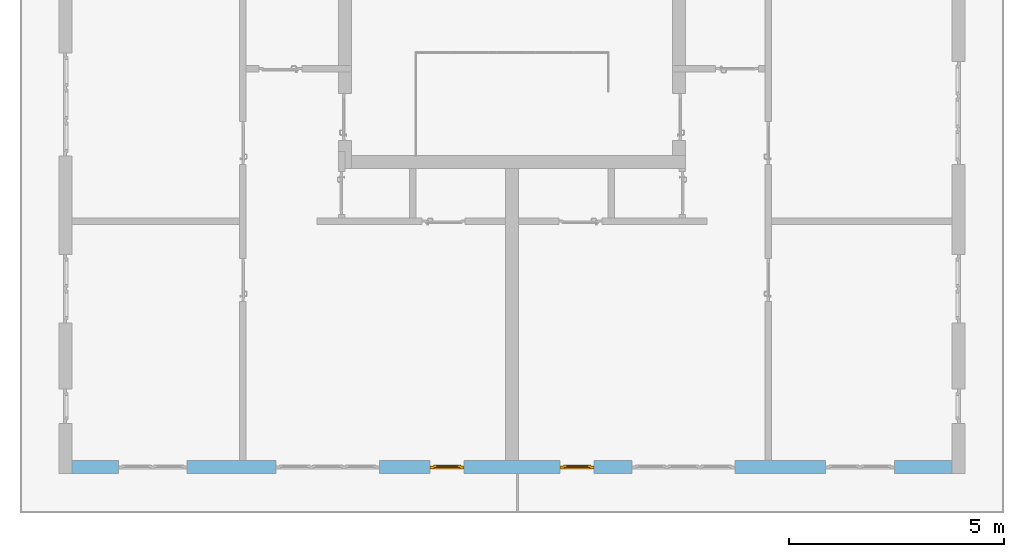
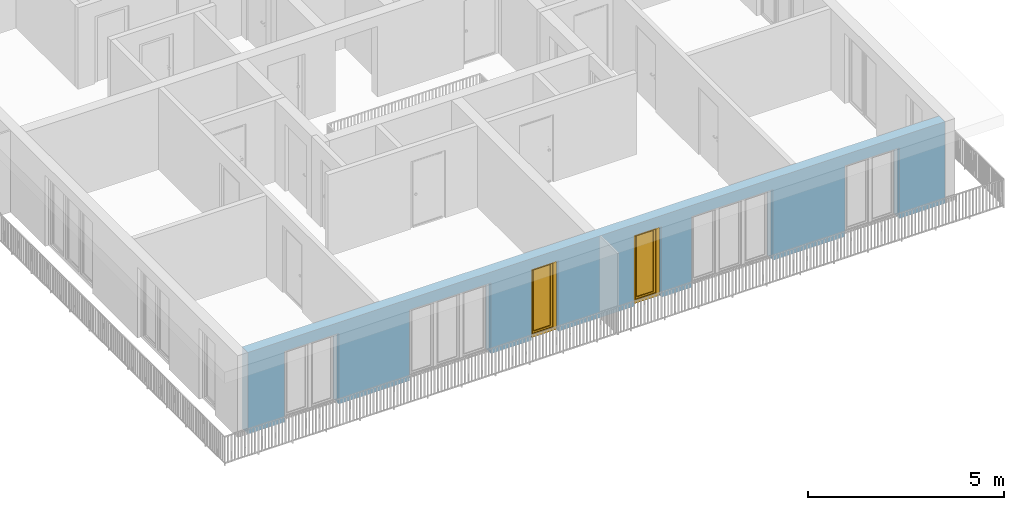
# One storey, part 10 of 54: 2 windows, 6 openings, plus 1 element that does not belong to this part.
"""IFC4 building model written with IfcOpenShell, lengths in metres."""

from ifc_helpers import new_model, entity, si_unit, converted_unit, derived_unit, direction, frame, origin_with_axes, place, context, subcontext, project, spatial, polygons, source, transform, mapped, material, type_object, element, fill, save


model = new_model("IFC4")

# Units and contexts
model_context = context("Model", 3, precision=1e-05, world=origin_with_axes(), true_north=direction((0.0, 1.0)))
body_context = subcontext(model_context, "Body", "Model", "MODEL_VIEW")
ifc_project = project(units=[si_unit("LENGTHUNIT", "METRE"), si_unit("AREAUNIT", "SQUARE_METRE"), si_unit("VOLUMEUNIT", "CUBIC_METRE"), converted_unit("PLANEANGLEUNIT", "DEGREE", entity("IfcPlaneAngleMeasure", 0.0174532925199), si_unit("PLANEANGLEUNIT", "RADIAN"), dimensions=[0, 0, 0, 0, 0, 0, 0]), converted_unit("TIMEUNIT", "Year", entity("IfcTimeMeasure", 31556926.0), si_unit("TIMEUNIT", "SECOND"), dimensions=[0, 0, 1, 0, 0, 0, 0]), si_unit("MASSUNIT", "GRAM", prefix="KILO"), si_unit("THERMODYNAMICTEMPERATUREUNIT", "DEGREE_CELSIUS"), si_unit("LUMINOUSINTENSITYUNIT", "LUMEN"), si_unit("ENERGYUNIT", "JOULE", prefix="MEGA"), derived_unit("THERMALCONDUCTANCEUNIT", [(si_unit("POWERUNIT", "WATT"), 1), (si_unit("LENGTHUNIT", "METRE"), -1), (si_unit("THERMODYNAMICTEMPERATUREUNIT", "KELVIN"), -1)]), derived_unit("SPECIFICHEATCAPACITYUNIT", [(si_unit("ENERGYUNIT", "JOULE"), 1), (si_unit("MASSUNIT", "GRAM", prefix="KILO"), -1), (si_unit("THERMODYNAMICTEMPERATUREUNIT", "KELVIN"), -1)]), derived_unit("MASSDENSITYUNIT", [(si_unit("MASSUNIT", "GRAM", prefix="KILO"), 1), (si_unit("VOLUMEUNIT", "CUBIC_METRE"), -1)])], contexts=[model_context])

# Site, building, storey
site_placement = place(None, origin_with_axes())
site = spatial("IfcSite", under=ifc_project, at=site_placement, CompositionType="ELEMENT")
building_placement = place(site_placement, origin_with_axes())
building = spatial("IfcBuilding", under=site, at=building_placement, CompositionType="ELEMENT")
storey_placement = place(building_placement, frame((0.0, 0.0, 9.18), z_axis=(0.0, 0.0, 1.0), x_axis=(1.0, 0.0, 0.0)))
storey = spatial("IfcBuildingStorey", under=building, at=storey_placement, Name="3. Geschoss", CompositionType="ELEMENT", Elevation=9.18)

# Wall, openings, windows
ifc_material = material()
wall_type = type_object("IfcWallType", Name="300", PredefinedType="NOTDEFINED")
wall_placement = place(storey_placement, frame((9.3378006196, -9.92881223104, 0.0), z_axis=(0.0, 0.0, 1.0), x_axis=(-1.0, 0.0, 0.0)))
wall = element("IfcWall", 1, at=wall_placement, inside=storey, type_object=wall_type, material=ifc_material, Name="Wand-001", PredefinedType="NOTDEFINED", context=body_context, shape_type="Tessellation", body=[
    polygons([(12.4515538751, -0.3, 2.2), (12.4515538751, -0.3, 0.0), (13.63, -0.3, 0.0), (13.63, -0.3, 2.2), (16.03, -0.3, 2.2), (16.03, -0.3, 0.0), (18.0998837323, -0.3, 0.0), (18.0998837323, -0.3, 2.2), (19.6998837323, -0.3, 2.2), (19.6998837323, -0.3, 0.0), (20.78, -0.3, 0.0), (20.78, -0.3, 2.54), (0.3, -0.3, 2.54), (0.3, -0.3, 0.0), (1.6378225413, -0.3, 0.0), (1.6378225413, -0.3, 2.2), (3.2378225413, -0.3, 2.2), (3.2378225413, -0.3, 0.0), (5.35, -0.3, 0.0), (5.35, -0.3, 2.2), (7.75, -0.3, 2.2), (7.75, -0.3, 0.0), (8.62617854928, -0.3, 0.0), (8.62617854928, -0.3, 2.2), (9.42617854928, -0.3, 2.2), (9.42617854928, -0.3, 0.0), (11.6515538751, -0.3, 0.0), (11.6515538751, -0.3, 2.2), (12.4515538751, -0.1, 0.0), (12.4515538751, 0.0, 2.2), (12.4515538751, 0.0, 0.0), (13.63, 0.0, 0.0), (13.63, 0.0, 2.2), (16.03, 0.0, 2.2), (16.03, 0.0, 0.0), (18.0998837323, 0.0, 0.0), (18.0998837323, 0.0, 2.2), (19.6998837323, 0.0, 2.2), (19.6998837323, 0.0, 0.0), (20.78, 0.0, 0.0), (20.78, 0.0, 2.54), (0.3, 0.0, 2.54), (0.3, 0.0, 0.0), (1.6378225413, 0.0, 0.0), (1.6378225413, 0.0, 2.2), (3.2378225413, 0.0, 2.2), (3.2378225413, 0.0, 0.0), (5.35, 0.0, 0.0), (5.35, 0.0, 2.2), (7.75, 0.0, 2.2), (7.75, 0.0, 0.0), (8.62617854928, 0.0, 0.0), (8.62617854928, 0.0, 2.2), (9.42617854928, 0.0, 2.2), (9.42617854928, 0.0, 0.0), (11.6515538751, -0.1, 0.0), (11.6515538751, 0.0, 0.0), (11.6515538751, 0.0, 2.2)], [[[1, 2, 3, 4, 5, 6, 7, 8, 9, 10, 11, 12, 13, 14, 15, 16, 17, 18, 19, 20, 21, 22, 23, 24, 25, 26, 27, 28]], [[29, 2, 1, 30, 31]], [[2, 29, 31, 32, 3]], [[32, 33, 4, 3]], [[33, 34, 5, 4]], [[34, 35, 6, 5]], [[36, 7, 6, 35]], [[36, 37, 8, 7]], [[37, 38, 9, 8]], [[38, 39, 10, 9]], [[40, 11, 10, 39]], [[40, 41, 12, 11]], [[41, 42, 13, 12]], [[14, 13, 42, 43]], [[15, 14, 43, 44]], [[16, 15, 44, 45]], [[17, 16, 45, 46]], [[18, 17, 46, 47]], [[19, 18, 47, 48]], [[20, 19, 48, 49]], [[21, 20, 49, 50]], [[22, 21, 50, 51]], [[51, 52, 23, 22]], [[52, 53, 24, 23]], [[53, 54, 25, 24]], [[54, 55, 26, 25]], [[56, 27, 26, 55, 57]], [[28, 27, 56, 57, 58]], [[1, 28, 58, 30]], [[32, 31, 30, 58, 57, 55, 54, 53, 52, 51, 50, 49, 48, 47, 46, 45, 44, 43, 42, 41, 40, 39, 38, 37, 36, 35, 34, 33]]], closed=True),
])
opening_1_placement = place(wall_placement, frame((18.8998837323, 0.0, 0.0), z_axis=(0.0, 0.0, 1.0), x_axis=(1.0, 0.0, 0.0)))
element("IfcOpeningElement", 2, at=opening_1_placement, cuts=wall, Name="Fenster-001", context=body_context, identifier="Reference", shape_type="Tessellation", body=[
    polygons([(-0.8, -0.1, 0.0), (-0.8, -0.1, 2.2), (-0.8, 0.001, 2.2), (-0.8, 0.001, 0.0), (-0.8, -0.301, 0.0), (-0.8, -0.301, 2.2), (0.8, -0.1, 2.2), (0.8, 0.001, 2.2), (0.8, -0.301, 2.2), (0.8, 0.001, 0.0), (0.8, -0.1, 0.0), (0.8, -0.301, 0.0)], [[[1, 2, 3, 4]], [[2, 1, 5, 6]], [[7, 8, 3, 2, 6, 9]], [[8, 10, 4, 3]], [[1, 4, 10, 11, 12, 5]], [[6, 5, 12, 9]], [[7, 11, 10, 8]], [[11, 7, 9, 12]]], closed=True),
])
opening_2_placement = place(wall_placement, frame((2.4378225413, 0.0, 0.0), z_axis=(0.0, 0.0, 1.0), x_axis=(1.0, 0.0, 0.0)))
element("IfcOpeningElement", 3, at=opening_2_placement, cuts=wall, Name="Fenster-002", context=body_context, identifier="Reference", shape_type="Tessellation", body=[
    polygons([(-0.8, -0.1, 0.0), (-0.8, -0.1, 2.2), (-0.8, 0.000999999999999, 2.2), (-0.8, 0.000999999999999, 0.0), (-0.8, -0.301, 0.0), (-0.8, -0.301, 2.2), (0.8, -0.1, 2.2), (0.8, 0.000999999999999, 2.2), (0.8, -0.301, 2.2), (0.8, 0.000999999999999, 0.0), (0.8, -0.1, 0.0), (0.8, -0.301, 0.0)], [[[1, 2, 3, 4]], [[2, 1, 5, 6]], [[7, 8, 3, 2, 6, 9]], [[8, 10, 4, 3]], [[1, 4, 10, 11, 12, 5]], [[6, 5, 12, 9]], [[7, 11, 10, 8]], [[11, 7, 9, 12]]], closed=True),
])
opening_3_placement = place(wall_placement, frame((14.83, 0.0, 0.0), z_axis=(0.0, 0.0, 1.0), x_axis=(1.0, 0.0, 0.0)))
element("IfcOpeningElement", 4, at=opening_3_placement, cuts=wall, Name="Fenster-002", context=body_context, identifier="Reference", shape_type="Tessellation", body=[
    polygons([(-1.2, -0.1, 0.0), (-1.2, -0.1, 2.2), (-1.2, 0.001, 2.2), (-1.2, 0.001, 0.0), (-1.2, -0.301, 0.0), (-1.2, -0.301, 2.2), (1.2, -0.1, 2.2), (1.2, 0.001, 2.2), (1.2, -0.301, 2.2), (1.2, 0.001, 0.0), (1.2, -0.1, 0.0), (1.2, -0.301, 0.0)], [[[1, 2, 3, 4]], [[2, 1, 5, 6]], [[7, 8, 3, 2, 6, 9]], [[8, 10, 4, 3]], [[1, 4, 10, 11, 12, 5]], [[6, 5, 12, 9]], [[7, 11, 10, 8]], [[11, 7, 9, 12]]], closed=True),
])
opening_4_placement = place(wall_placement, frame((6.55, 0.0, 0.0), z_axis=(0.0, 0.0, 1.0), x_axis=(1.0, 0.0, 0.0)))
element("IfcOpeningElement", 5, at=opening_4_placement, cuts=wall, Name="Fenster-003", context=body_context, identifier="Reference", shape_type="Tessellation", body=[
    polygons([(-1.2, -0.1, 0.0), (-1.2, -0.1, 2.2), (-1.2, 0.000999999999999, 2.2), (-1.2, 0.000999999999999, 0.0), (-1.2, -0.301, 0.0), (-1.2, -0.301, 2.2), (1.2, -0.1, 2.2), (1.2, 0.001, 2.2), (1.2, -0.301, 2.2), (1.2, 0.001, 0.0), (1.2, -0.1, 0.0), (1.2, -0.301, 0.0)], [[[1, 2, 3, 4]], [[2, 1, 5, 6]], [[7, 8, 3, 2, 6, 9]], [[8, 10, 4, 3]], [[1, 4, 10, 11, 12, 5]], [[6, 5, 12, 9]], [[7, 11, 10, 8]], [[11, 7, 9, 12]]], closed=True),
])
opening_5_placement = place(wall_placement, frame((9.02617854928, 0.0, 0.0), z_axis=(0.0, 0.0, 1.0), x_axis=(1.0, 0.0, 0.0)))
opening_5 = element("IfcOpeningElement", 6, at=opening_5_placement, cuts=wall, Name="Fenster-003", context=body_context, identifier="Reference", shape_type="Tessellation", body=[
    polygons([(-0.4, -0.1, 0.0), (-0.4, -0.1, 2.2), (-0.4, 0.001, 2.2), (-0.4, 0.001, 0.0), (-0.4, -0.301, 0.0), (-0.4, -0.301, 2.2), (0.4, -0.1, 2.2), (0.4, 0.001, 2.2), (0.4, -0.301, 2.2), (0.4, 0.001, 0.0), (0.4, -0.1, 0.0), (0.4, -0.301, 0.0)], [[[1, 2, 3, 4]], [[2, 1, 5, 6]], [[7, 8, 3, 2, 6, 9]], [[8, 10, 4, 3]], [[1, 4, 10, 11, 12, 5]], [[6, 5, 12, 9]], [[7, 11, 10, 8]], [[11, 7, 9, 12]]], closed=True),
])
opening_6_placement = place(wall_placement, frame((12.0515538751, 0.0, 0.0), z_axis=(0.0, 0.0, 1.0), x_axis=(1.0, 0.0, 0.0)))
opening_6 = element("IfcOpeningElement", 7, at=opening_6_placement, cuts=wall, Name="Fenster-003", context=body_context, identifier="Reference", shape_type="Tessellation", body=[
    polygons([(-0.4, -0.1, 0.0), (-0.4, -0.1, 2.2), (-0.4, 0.001, 2.2), (-0.4, 0.001, 0.0), (-0.4, -0.301, 0.0), (-0.4, -0.301, 2.2), (0.4, -0.1, 2.2), (0.4, 0.001, 2.2), (0.4, -0.301, 2.2), (0.4, 0.001, 0.0), (0.4, -0.1, 0.0), (0.4, -0.301, 0.0)], [[[1, 2, 3, 4]], [[2, 1, 5, 6]], [[7, 8, 3, 2, 6, 9]], [[8, 10, 4, 3]], [[1, 4, 10, 11, 12, 5]], [[6, 5, 12, 9]], [[7, 11, 10, 8]], [[11, 7, 9, 12]]], closed=True),
])
window_type = type_object("IfcWindowType", Name="1-26", PartitioningType="SINGLE_PANEL", PredefinedType="WINDOW")
shared_shape = source(origin_with_axes(), body_context, "Body", "Tessellation", [
    polygons([(-0.4, -0.07, 0.0), (-0.4, 0.0, 0.0), (-0.3, 0.0, 0.1), (-0.3, -0.07, 0.1), (-0.4, -0.07, 2.2), (-0.4, 0.0, 2.2), (-0.3, 0.0, 2.1), (-0.3, -0.07, 2.1)], [[[1, 2, 3, 4]], [[5, 6, 2, 1]], [[2, 6, 7, 3]], [[4, 3, 7, 8]], [[1, 4, 8, 5]], [[8, 7, 6, 5]]], closed=True),
    polygons([(0.4, -0.07, 0.0), (0.4, 0.0, 0.0), (0.4, 0.0, 2.2), (0.4, -0.07, 2.2), (0.3, -0.07, 0.1), (0.3, 0.0, 0.1), (0.3, 0.0, 2.1), (0.3, -0.07, 2.1)], [[[1, 2, 3, 4]], [[5, 6, 2, 1]], [[2, 6, 7, 3]], [[4, 3, 7, 8]], [[1, 4, 8, 5]], [[8, 7, 6, 5]]], closed=True),
    polygons([(-0.4, -0.07, 0.0), (-0.4, 0.0, 0.0), (0.4, 0.0, 0.0), (0.4, -0.07, 0.0), (-0.3, -0.07, 0.1), (-0.3, 0.0, 0.1), (0.0, 0.0, 0.1), (0.3, 0.0, 0.1), (0.3, -0.07, 0.1), (0.0, -0.07, 0.1)], [[[1, 2, 3, 4]], [[5, 6, 2, 1]], [[2, 6, 7, 8, 3]], [[4, 3, 8, 9]], [[1, 4, 9, 10, 5]], [[10, 7, 6, 5]], [[9, 8, 7, 10]]], closed=True),
    polygons([(-0.4, -0.07, 2.2), (-0.4, 0.0, 2.2), (-0.3, 0.0, 2.1), (-0.3, -0.07, 2.1), (0.4, -0.07, 2.2), (0.4, 0.0, 2.2), (0.3, 0.0, 2.1), (0.0, 0.0, 2.1), (0.0, -0.07, 2.1), (0.3, -0.07, 2.1)], [[[1, 2, 3, 4]], [[5, 6, 2, 1]], [[2, 6, 7, 8, 3]], [[4, 3, 8, 9]], [[1, 4, 9, 10, 5]], [[10, 7, 6, 5]], [[9, 8, 7, 10]]], closed=True),
    polygons([(-0.32, 0.0, 0.08), (-0.32, 0.03, 0.08), (-0.25, 0.03, 0.15), (-0.25, 0.0, 0.15), (-0.32, 0.0, 2.12), (-0.32, 0.03, 2.12), (-0.25, 0.03, 2.05), (-0.25, 0.0, 2.05)], [[[1, 2, 3, 4]], [[5, 6, 2, 1]], [[2, 6, 7, 3]], [[4, 3, 7, 8]], [[1, 4, 8, 5]], [[8, 7, 6, 5]]], closed=True),
    polygons([(0.32, 0.0, 0.08), (0.25, 0.0, 0.15), (0.25, 0.03, 0.15), (0.32, 0.03, 0.08), (0.32, 0.0, 2.12), (0.25, 0.0, 2.05), (0.25, 0.03, 2.05), (0.32, 0.03, 2.12)], [[[1, 2, 3, 4]], [[1, 5, 6, 2]], [[2, 6, 7, 3]], [[4, 3, 7, 8]], [[5, 1, 4, 8]], [[6, 5, 8, 7]]], closed=True),
    polygons([(-0.32, 0.0, 0.08), (-0.32, 0.03, 0.08), (0.32, 0.03, 0.08), (0.32, 0.0, 0.08), (-0.25, 0.0, 0.15), (-0.25, 0.03, 0.15), (0.25, 0.03, 0.15), (0.25, 0.0, 0.15)], [[[1, 2, 3, 4]], [[5, 6, 2, 1]], [[2, 6, 7, 3]], [[4, 3, 7, 8]], [[1, 4, 8, 5]], [[8, 7, 6, 5]]], closed=True),
    polygons([(-0.32, 0.0, 2.12), (0.32, 0.0, 2.12), (0.32, 0.03, 2.12), (-0.32, 0.03, 2.12), (-0.25, 0.0, 2.05), (0.25, 0.0, 2.05), (0.25, 0.03, 2.05), (-0.25, 0.03, 2.05)], [[[1, 2, 3, 4]], [[1, 5, 6, 2]], [[2, 6, 7, 3]], [[4, 3, 7, 8]], [[5, 1, 4, 8]], [[6, 5, 8, 7]]], closed=True),
    polygons([(-0.3, -0.03, 0.1), (-0.3, 0.0, 0.1), (-0.25, 0.0, 0.15), (-0.25, -0.03, 0.15), (-0.3, -0.03, 2.1), (-0.3, 0.0, 2.1), (-0.25, 0.0, 2.05), (-0.25, -0.03, 2.05)], [[[1, 2, 3, 4]], [[5, 6, 2, 1]], [[2, 6, 7, 3]], [[4, 3, 7, 8]], [[1, 4, 8, 5]], [[8, 7, 6, 5]]], closed=True),
    polygons([(0.3, -0.03, 0.1), (0.25, -0.03, 0.15), (0.25, 0.0, 0.15), (0.3, 0.0, 0.1), (0.3, -0.03, 2.1), (0.25, -0.03, 2.05), (0.25, 0.0, 2.05), (0.3, 0.0, 2.1)], [[[1, 2, 3, 4]], [[1, 5, 6, 2]], [[2, 6, 7, 3]], [[4, 3, 7, 8]], [[5, 1, 4, 8]], [[6, 5, 8, 7]]], closed=True),
    polygons([(-0.3, -0.03, 0.1), (-0.3, 0.0, 0.1), (0.3, 0.0, 0.1), (0.3, -0.03, 0.1), (-0.25, -0.03, 0.15), (-0.25, 0.0, 0.15), (0.25, 0.0, 0.15), (0.25, -0.03, 0.15)], [[[1, 2, 3, 4]], [[5, 6, 2, 1]], [[2, 6, 7, 3]], [[4, 3, 7, 8]], [[1, 4, 8, 5]], [[8, 7, 6, 5]]], closed=True),
    polygons([(-0.3, -0.03, 2.1), (0.3, -0.03, 2.1), (0.3, 0.0, 2.1), (-0.3, 0.0, 2.1), (-0.25, -0.03, 2.05), (0.25, -0.03, 2.05), (0.25, 0.0, 2.05), (-0.25, 0.0, 2.05)], [[[1, 2, 3, 4]], [[1, 5, 6, 2]], [[2, 6, 7, 3]], [[4, 3, 7, 8]], [[5, 1, 4, 8]], [[6, 5, 8, 7]]], closed=True),
    polygons([(-0.25, -0.005, 0.15), (-0.25, 0.005, 0.15), (0.25, 0.005, 0.15), (0.25, -0.005, 0.15), (-0.25, -0.005, 2.05), (-0.25, 0.005, 2.05), (0.25, 0.005, 2.05), (0.25, -0.005, 2.05)], [[[1, 2, 3, 4]], [[5, 6, 2, 1]], [[2, 6, 7, 3]], [[4, 3, 7, 8]], [[1, 4, 8, 5]], [[8, 7, 6, 5]]], closed=True),
])
window_1_placement = place(opening_5_placement, frame((0.4, 0.0, 0.0), z_axis=(0.0, 0.0, 1.0), x_axis=(-1.0, 0.0, 0.0)))
window_1 = element("IfcWindow", 8, at=window_1_placement, inside=storey, type_object=window_type, Name="Fenster-003", OverallHeight=2.2, OverallWidth=0.8, PredefinedType="WINDOW", context=body_context, shape_type="MappedRepresentation", body=[
    mapped(shared_shape, transform((0.4, 0.17, 0.0))),
])
fill(opening_5, window_1)
window_2_placement = place(opening_6_placement, frame((0.4, 0.0, 0.0), z_axis=(0.0, 0.0, 1.0), x_axis=(-1.0, 0.0, 0.0)))
window_2 = element("IfcWindow", 9, at=window_2_placement, inside=storey, type_object=window_type, Name="Fenster-003", OverallHeight=2.2, OverallWidth=0.8, PredefinedType="WINDOW", context=body_context, shape_type="MappedRepresentation", body=[
    mapped(shared_shape, transform((0.4, 0.17, 0.0))),
])
fill(opening_6, window_2)

save(model, "model.ifc")
